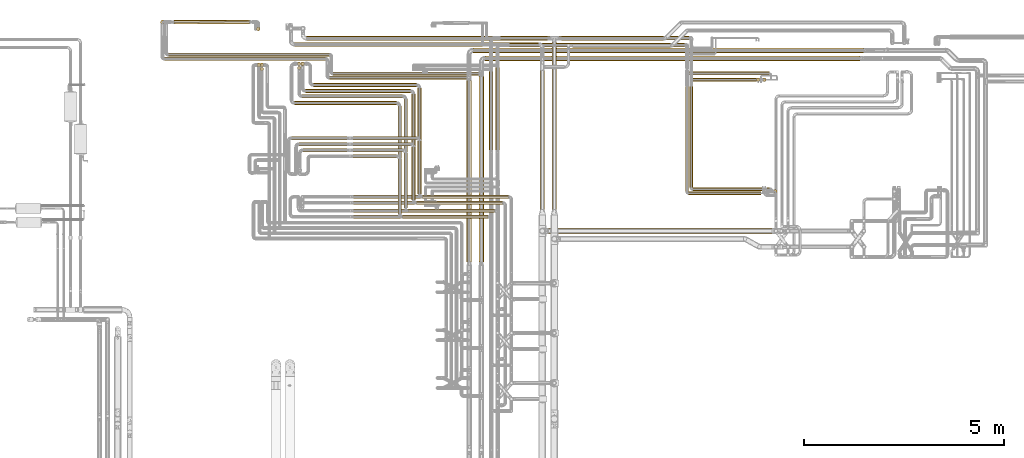
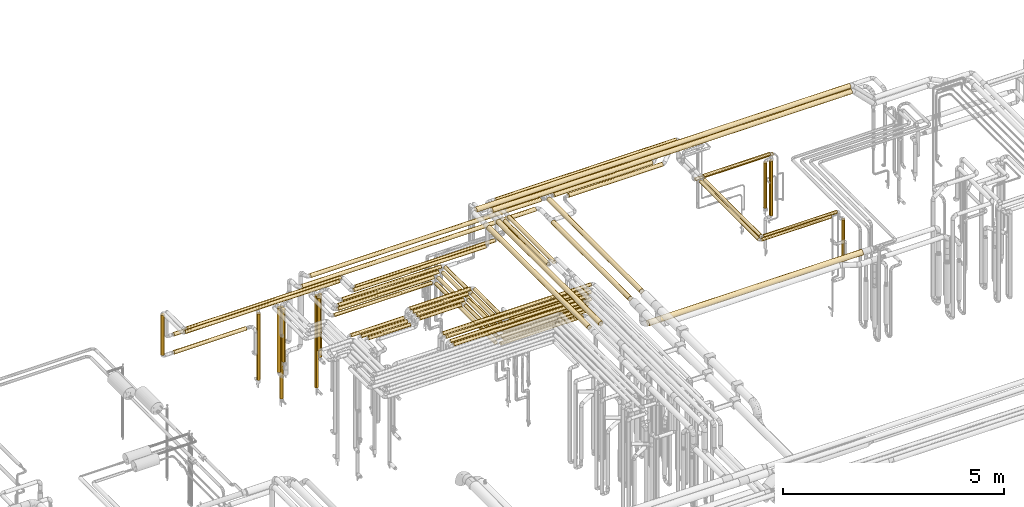
# One storey, part 6 of 827: 69 coverings.
"""IFC2X3 building model written with IfcOpenShell, lengths in millimetres."""

import ifcopenshell
import ifcopenshell.guid

model = None  # the IFC model being written
_history = None  # IfcOwnerHistory: only IFC2X3 demands one
_inside = {}  # id of a spatial element -> (the spatial element, [elements in it])
_under = {}  # id of a project, library or spatial element -> (it, [spatial elements below it])
_declared = {}  # id of a project -> (the project, [libraries it declares])
_typed = {}  # id of a type object -> (the type object, [elements of that type])
_made_of = {}  # id of a material, layer set ... -> (it, [elements and type objects made of it])


def new_model(schema):
    """Start an empty IFC model of exactly this schema.

    Asked for "IFC4X3", IfcOpenShell would pick the latest addendum, in which some entities
    have other attributes; the version numbers below select the first issue.
    IFC2X3 requires an IfcOwnerHistory on every rooted entity: one is made here for all.
    """
    global model, _history
    if schema == "IFC4X3":
        model = ifcopenshell.file(schema_version=(4, 3, 0, 0))
    else:
        model = ifcopenshell.file(schema=schema)
    _inside.clear()
    _under.clear()
    _declared.clear()
    _typed.clear()
    _made_of.clear()
    _history = None
    if model.schema == "IFC2X3":
        org = make("IfcOrganization", Name="unknown")
        user = make(
            "IfcPersonAndOrganization",
            ThePerson=make("IfcPerson", FamilyName="unknown"),
            TheOrganization=org,
        )
        app = make(
            "IfcApplication",
            ApplicationDeveloper=org,
            Version="unknown",
            ApplicationFullName="unknown",
            ApplicationIdentifier="unknown",
        )
        _history = make(
            "IfcOwnerHistory",
            OwningUser=user,
            OwningApplication=app,
            ChangeAction="ADDED",
            CreationDate=0,
        )
    return model


def make(cls, **values):
    """One entity of the class cls with the attributes given. An attribute that is None is left unset."""
    return model.create_entity(
        cls, **{name: value for name, value in values.items() if value is not None}
    )


def entity(cls, *values):
    """Any entity or typed value of the class cls, its attributes in the order of the schema. None: left unset."""
    e = model.create_entity(cls)
    for i, value in enumerate(values):
        if value is not None:
            e[i] = value
    return e


def rooted(cls, **values):
    """An entity with a GlobalId (a new one), such as an element, a storey or a relation."""
    return make(cls, GlobalId=ifcopenshell.guid.new(), OwnerHistory=_history, **values)


def si_unit(unit_type, name, prefix=None):
    """IfcSIUnit, for example si_unit("LENGTHUNIT", "METRE", prefix="MILLI")."""
    return make("IfcSIUnit", UnitType=unit_type, Prefix=prefix, Name=name)


def converted_unit(unit_type, name, factor, base, dimensions=None, offset=None):
    """IfcConversionBasedUnit, such as the inch: factor (a typed value) times the base unit."""
    return make(
        "IfcConversionBasedUnit"
        if offset is None
        else "IfcConversionBasedUnitWithOffset",
        ConversionOffset=offset,
        Dimensions=None
        if dimensions is None
        else entity("IfcDimensionalExponents", *dimensions),
        UnitType=unit_type,
        Name=name,
        ConversionFactor=make(
            "IfcMeasureWithUnit", ValueComponent=factor, UnitComponent=base
        ),
    )


def derived_unit(unit_type, elements):
    """IfcDerivedUnit: a product of units, each with its exponent."""
    return make(
        "IfcDerivedUnit",
        Elements=[
            make("IfcDerivedUnitElement", Unit=unit, Exponent=power)
            for unit, power in elements
        ],
        UnitType=unit_type,
    )


def assignment(units):
    """IfcUnitAssignment: the units of a project."""
    return None if units is None else make("IfcUnitAssignment", Units=units)


def point(xyz):
    """IfcCartesianPoint."""
    return None if xyz is None else make("IfcCartesianPoint", Coordinates=xyz)


def direction(xyz):
    """IfcDirection."""
    return None if xyz is None else make("IfcDirection", DirectionRatios=xyz)


def frame(location, z_axis=None, x_axis=None):
    """IfcAxis2Placement3D, a coordinate frame: its origin and axes. An axis left out is left unset."""
    return make(
        "IfcAxis2Placement3D",
        Location=point(location),
        Axis=direction(z_axis),
        RefDirection=direction(x_axis),
    )


def frame_2d(location, x_axis=None):
    """IfcAxis2Placement2D, a coordinate frame in the plane: its origin and x axis."""
    return make(
        "IfcAxis2Placement2D", Location=point(location), RefDirection=direction(x_axis)
    )


def origin():
    """The frame at (0, 0, 0) with its axes left unset."""
    return frame((0.0, 0.0, 0.0))


def origin_2d_with_axis():
    """The frame at (0, 0) in the plane with the x axis (1, 0) written out."""
    return frame_2d((0.0, 0.0), x_axis=(1.0, 0.0))


def place(relative_to, where):
    """IfcLocalPlacement: puts the frame where relative to a parent placement (None: the world)."""
    return make(
        "IfcLocalPlacement", PlacementRelTo=relative_to, RelativePlacement=where
    )


def context(
    kind, dimensions, precision=None, world=None, true_north=None, identifier=None
):
    """IfcGeometricRepresentationContext, for example the 3D "Model" context."""
    return make(
        "IfcGeometricRepresentationContext",
        ContextIdentifier=identifier,
        ContextType=kind,
        CoordinateSpaceDimension=dimensions,
        Precision=precision,
        WorldCoordinateSystem=world,
        TrueNorth=true_north,
    )


def subcontext(parent, identifier, kind, view, scale=None):
    """IfcGeometricRepresentationSubContext, for example "Body" below "Model"."""
    return make(
        "IfcGeometricRepresentationSubContext",
        ContextIdentifier=identifier,
        ContextType=kind,
        ParentContext=parent,
        TargetScale=scale,
        TargetView=view,
    )


def project(units=None, contexts=None):
    """IfcProject with its units and contexts."""
    return rooted(
        "IfcProject",
        Name="project",
        RepresentationContexts=contexts,
        UnitsInContext=assignment(units),
    )


def spatial(cls, under=None, at=None, **own):
    """A site, building, storey or space (cls), placed at a placement, below another one or the project."""
    s = rooted(cls, ObjectPlacement=at, **own)
    if under is not None:
        _under.setdefault(under.id(), (under, []))[1].append(s)
    return s


def polyline(points):
    """IfcPolyline through the points."""
    return make("IfcPolyline", Points=[point(p) for p in points])


def profile(cls, at=None, kind="AREA", **sizes):
    """A parametric profile (cls). Its sizes go by their IFC names, for example OverallWidth=200.0."""
    return make(cls, ProfileType=kind, Position=at, **sizes)


def circle(**sizes):
    """IfcCircleProfileDef."""
    return profile("IfcCircleProfileDef", **sizes)


def outline(outer, holes=None, kind="AREA"):
    """IfcArbitraryClosedProfileDef: a profile drawn as a closed curve; with holes, ...WithVoids."""
    if holes is None:
        return make("IfcArbitraryClosedProfileDef", ProfileType=kind, OuterCurve=outer)
    return make(
        "IfcArbitraryProfileDefWithVoids",
        ProfileType=kind,
        OuterCurve=outer,
        InnerCurves=holes,
    )


def extrude(swept, where, along, depth):
    """IfcExtrudedAreaSolid: the profile swept, set in the frame where, extruded along a direction by depth."""
    return make(
        "IfcExtrudedAreaSolid",
        SweptArea=swept,
        Position=where,
        ExtrudedDirection=direction(along),
        Depth=depth,
    )


def shape(context_of_items, identifier, shape_type, items):
    """IfcShapeRepresentation: the items that make up one representation, for example the "Body"."""
    return make(
        "IfcShapeRepresentation",
        ContextOfItems=context_of_items,
        RepresentationIdentifier=identifier,
        RepresentationType=shape_type,
        Items=items,
    )


def made_of(thing, what):
    """Note that an element or type object is made of a material, layer set ...; save() writes the relation."""
    if what is not None:
        _made_of.setdefault(what.id(), (what, []))[1].append(thing)
    return thing


def element(
    cls,
    number,
    at=None,
    inside=None,
    cuts=None,
    type_object=None,
    material=None,
    context=None,
    identifier="Body",
    shape_type=None,
    held_by="IfcProductDefinitionShape",
    body=None,
    shapes=None,
    **own,
):
    """One element of the class cls, such as IfcWall. Its Tag is "e" and its number.

    at: its placement. inside: the storey or other place that contains it. cuts: it is an
    opening in that element (IfcRelVoidsElement). A single representation is given by context,
    identifier, shape_type and body (its items); several are given by shapes. held_by: the class
    of the entity that holds the representations. save() writes the other relations.
    """
    e = rooted(cls, Tag="e%d" % number, ObjectPlacement=at, **own)
    if body is not None:
        shapes = [shape(context, identifier, shape_type, body)]
    if shapes is not None:
        e.Representation = make(held_by, Representations=shapes)
    if inside is not None:
        _inside.setdefault(inside.id(), (inside, []))[1].append(e)
    if cuts is not None:
        rooted(
            "IfcRelVoidsElement", RelatingBuildingElement=cuts, RelatedOpeningElement=e
        )
    if type_object is not None:
        _typed.setdefault(type_object.id(), (type_object, []))[1].append(e)
    return made_of(e, material)


def aggregate(whole, parts):
    """IfcRelAggregates: a whole, such as a stair, and the parts it consists of."""
    return rooted("IfcRelAggregates", RelatingObject=whole, RelatedObjects=parts)


def save(model, path):
    """Write the relations noted so far, then the file.

    IfcRelAggregates (storeys below a building ...), IfcRelContainedInSpatialStructure (elements
    in a storey), IfcRelDefinesByType, IfcRelAssociatesMaterial and IfcRelDeclares: one each for
    every whole, place, type object, material and project.
    """
    for whole, parts in _under.values():
        aggregate(whole, parts)
    for where, things in _inside.values():
        rooted(
            "IfcRelContainedInSpatialStructure",
            RelatedElements=things,
            RelatingStructure=where,
        )
    for kind, things in _typed.values():
        rooted("IfcRelDefinesByType", RelatedObjects=things, RelatingType=kind)
    for what, things in _made_of.values():
        rooted("IfcRelAssociatesMaterial", RelatedObjects=things, RelatingMaterial=what)
    for by, libraries in _declared.values():
        rooted("IfcRelDeclares", RelatingContext=by, RelatedDefinitions=libraries)
    model.write(path)


model = new_model("IFC2X3")

# Units and contexts
model_context = context("Model", 3, precision=0.01, world=origin(), true_north=direction((6.12303176911189e-17, 1.0)))
body_context = subcontext(model_context, "Body", "Model", "MODEL_VIEW")
ifc_project = project(units=[si_unit("LENGTHUNIT", "METRE", prefix="MILLI"), si_unit("AREAUNIT", "SQUARE_METRE"), si_unit("VOLUMEUNIT", "CUBIC_METRE"), converted_unit("PLANEANGLEUNIT", "DEGREE", entity("IfcRatioMeasure", 0.0174532925199433), si_unit("PLANEANGLEUNIT", "RADIAN"), dimensions=[0, 0, 0, 0, 0, 0, 0]), si_unit("MASSUNIT", "GRAM", prefix="KILO"), derived_unit("MASSDENSITYUNIT", [(si_unit("MASSUNIT", "GRAM", prefix="KILO"), 1), (si_unit("LENGTHUNIT", "METRE"), -3)]), derived_unit("MOMENTOFINERTIAUNIT", [(si_unit("LENGTHUNIT", "METRE"), 4)]), si_unit("TIMEUNIT", "SECOND"), si_unit("FREQUENCYUNIT", "HERTZ"), si_unit("THERMODYNAMICTEMPERATUREUNIT", "DEGREE_CELSIUS"), derived_unit("THERMALTRANSMITTANCEUNIT", [(si_unit("MASSUNIT", "GRAM", prefix="KILO"), 1), (si_unit("THERMODYNAMICTEMPERATUREUNIT", "KELVIN"), -1), (si_unit("TIMEUNIT", "SECOND"), -3)]), derived_unit("VOLUMETRICFLOWRATEUNIT", [(si_unit("LENGTHUNIT", "METRE"), 3), (si_unit("TIMEUNIT", "SECOND"), -1)]), derived_unit("MASSFLOWRATEUNIT", [(si_unit("MASSUNIT", "GRAM", prefix="KILO"), 1), (si_unit("TIMEUNIT", "SECOND"), -1)]), derived_unit("ROTATIONALFREQUENCYUNIT", [(si_unit("TIMEUNIT", "SECOND"), -1)]), si_unit("ELECTRICCURRENTUNIT", "AMPERE"), si_unit("ELECTRICVOLTAGEUNIT", "VOLT"), si_unit("POWERUNIT", "WATT"), si_unit("FORCEUNIT", "NEWTON", prefix="KILO"), si_unit("ILLUMINANCEUNIT", "LUX"), si_unit("LUMINOUSFLUXUNIT", "LUMEN"), si_unit("LUMINOUSINTENSITYUNIT", "CANDELA"), derived_unit("USERDEFINED", [(si_unit("MASSUNIT", "GRAM", prefix="KILO"), -1), (si_unit("LENGTHUNIT", "METRE"), -2), (si_unit("TIMEUNIT", "SECOND"), 3), (si_unit("LUMINOUSFLUXUNIT", "LUMEN"), 1)]), derived_unit("LINEARVELOCITYUNIT", [(si_unit("LENGTHUNIT", "METRE"), 1), (si_unit("TIMEUNIT", "SECOND"), -1)]), si_unit("PRESSUREUNIT", "PASCAL"), derived_unit("USERDEFINED", [(si_unit("LENGTHUNIT", "METRE"), -2), (si_unit("MASSUNIT", "GRAM", prefix="KILO"), 1), (si_unit("TIMEUNIT", "SECOND"), -2)]), derived_unit("LINEARFORCEUNIT", [(si_unit("MASSUNIT", "GRAM", prefix="KILO"), 1), (si_unit("LENGTHUNIT", "METRE"), 1), (si_unit("TIMEUNIT", "SECOND"), -2), (si_unit("LENGTHUNIT", "METRE"), -1)]), derived_unit("PLANARFORCEUNIT", [(si_unit("MASSUNIT", "GRAM", prefix="KILO"), 1), (si_unit("LENGTHUNIT", "METRE"), 1), (si_unit("TIMEUNIT", "SECOND"), -2), (si_unit("LENGTHUNIT", "METRE"), -2)])], contexts=[model_context])

# Site, building, storey
site_placement = place(None, origin())
site = spatial("IfcSite", under=ifc_project, at=site_placement, CompositionType="ELEMENT")
building_placement = place(site_placement, origin())
building = spatial("IfcBuilding", under=site, at=building_placement, CompositionType="ELEMENT")
storey_placement = place(building_placement, frame((0.0, 0.0, 28200.0)))
storey = spatial("IfcBuildingStorey", under=building, at=storey_placement, Name="08", CompositionType="ELEMENT", Elevation=28200.0)

# Coverings
covering_1_placement = place(storey_placement, frame((36012.93, 18744.53, 3485.65)))
element("IfcCovering", 1, at=covering_1_placement, inside=storey, Name=":ADSK_", ObjectType=":ADSK_", PredefinedType="INSULATION", context=body_context, shape_type="SweptSolid", body=[
    extrude(outline(polyline([(-8.19, -62.21), (8.19, -62.21), (24.01, -57.97), (38.2, -49.78), (49.78, -38.2), (57.97, -24.01), (62.21, -8.19), (62.21, 8.19), (57.97, 24.01), (49.78, 38.2), (38.2, 49.78), (24.01, 57.97), (8.19, 62.21), (-8.19, 62.21), (-24.01, 57.97), (-38.2, 49.78), (-49.78, 38.2), (-57.97, 24.01), (-62.21, 8.19), (-62.21, -8.19), (-57.97, -24.01), (-49.78, -38.2), (-38.2, -49.78), (-24.01, -57.97), (-8.19, -62.21)])), frame((0.0, 64.39, 64.35), z_axis=(1.0, -4.85826303863744e-06, 0.0), x_axis=(6.34811881532513e-07, 0.130526192218576, -0.991444861373802)), (0.0, 0.0, 1.0), 9771.5320502305),
])
covering_2_placement = place(storey_placement, frame((28192.29, 19468.46, 1848.0)))
element("IfcCovering", 2, at=covering_2_placement, inside=storey, Name=":ADSK_", ObjectType=":ADSK_", PredefinedType="INSULATION", context=body_context, shape_type="SweptSolid", body=[
    extrude(circle(Radius=46.15, at=origin_2d_with_axis()), frame((47.75, 47.75, 0.0)), (0.0, 0.0, 1.0), 1103.5044787345),
])
covering_3_placement = place(storey_placement, frame((28288.03, 18549.76, 2951.76)))
element("IfcCovering", 3, at=covering_3_placement, inside=storey, Name=":ADSK_", ObjectType=":ADSK_", PredefinedType="INSULATION", context=body_context, shape_type="SweptSolid", body=[
    extrude(circle(Radius=46.15, at=origin_2d_with_axis()), frame((0.0, 47.75, 47.75), z_axis=(1.0, 0.0, 0.0), x_axis=(0.0, 1.0, 0.0)), (0.0, 0.0, 1.0), 4034.00000000001),
])
covering_4_placement = place(storey_placement, frame((32418.03, 18077.16, 2951.76)))
element("IfcCovering", 4, at=covering_4_placement, inside=storey, Name=":ADSK_", ObjectType=":ADSK_", PredefinedType="INSULATION", context=body_context, shape_type="SweptSolid", body=[
    extrude(circle(Radius=46.15, at=origin_2d_with_axis()), frame((0.0, 47.75, 47.75), z_axis=(1.0, -2.64804923458862e-08, -1.57061026051097e-07), x_axis=(2.64804923458866e-08, 1.0, 0.0)), (0.0, 0.0, 1.0), 3452.34056165486),
])
covering_5_placement = place(storey_placement, frame((35853.75, 13506.7, 3485.65)))
element("IfcCovering", 5, at=covering_5_placement, inside=storey, Name=":ADSK_", ObjectType=":ADSK_", PredefinedType="INSULATION", context=body_context, shape_type="SweptSolid", body=[
    extrude(circle(Radius=62.75, at=origin_2d_with_axis()), frame((64.35, 0.0, 64.35), z_axis=(0.0, 1.0, -9.47129949639456e-08), x_axis=(-1.0, 0.0, 0.0)), (0.0, 0.0, 1.0), 4542.20661769209),
])
covering_6_placement = place(storey_placement, frame((28529.16, 19465.54, 1749.4)))
element("IfcCovering", 6, at=covering_6_placement, inside=storey, Name=":ADSK_", ObjectType=":ADSK_", PredefinedType="INSULATION", context=body_context, shape_type="SweptSolid", body=[
    extrude(circle(Radius=49.0, at=origin_2d_with_axis()), frame((0.06, 50.6, 50.6), z_axis=(0.999999363543567, 0.00112823422292339, 0.0), x_axis=(-0.00112823422292339, 0.999999363543567, 0.0)), (0.0, 0.0, 1.0), 1888.98967089916),
])
covering_7_placement = place(storey_placement, frame((30594.46, 19295.69, 423.0)))
element("IfcCovering", 7, at=covering_7_placement, inside=storey, Name=":ADSK_", ObjectType=":ADSK_", PredefinedType="INSULATION", context=body_context, shape_type="SweptSolid", body=[
    extrude(circle(Radius=46.15, at=origin_2d_with_axis()), frame((47.75, 47.75, 0.0)), (0.0, 0.0, 1.0), 1829.00000000023),
])
covering_8_placement = place(storey_placement, frame((36315.03, 18542.35, 3485.65)))
element("IfcCovering", 8, at=covering_8_placement, inside=storey, Name=":ADSK_", ObjectType=":ADSK_", PredefinedType="INSULATION", context=body_context, shape_type="SweptSolid", body=[
    extrude(circle(Radius=62.75, at=origin_2d_with_axis()), frame((0.0, 64.35, 64.35), z_axis=(1.0, 0.0, 0.0), x_axis=(0.0, -1.0, 0.0)), (0.0, 0.0, 1.0), 9389.4356787662),
])
covering_9_placement = place(storey_placement, frame((36155.69, 13506.7, 3485.65)))
element("IfcCovering", 9, at=covering_9_placement, inside=storey, Name=":ADSK_", ObjectType=":ADSK_", PredefinedType="INSULATION", context=body_context, shape_type="SweptSolid", body=[
    extrude(circle(Radius=62.75, at=origin_2d_with_axis()), frame((64.35, 0.0, 64.35), z_axis=(0.0, 1.0, 0.0), x_axis=(1.0, 0.0, 0.0)), (0.0, 0.0, 1.0), 4642.2472086319),
])
covering_10_placement = place(storey_placement, frame((28388.03, 18652.26, 2952.16)))
element("IfcCovering", 10, at=covering_10_placement, inside=storey, Name=":ADSK_", ObjectType=":ADSK_", PredefinedType="INSULATION", context=body_context, shape_type="SweptSolid", body=[
    extrude(circle(Radius=46.15, at=origin_2d_with_axis()), frame((0.0, 47.75, 47.75), z_axis=(1.0, 0.0, 0.0), x_axis=(0.0, 1.0, 0.0)), (0.0, 0.0, 1.0), 4031.49999999999),
])
covering_11_placement = place(storey_placement, frame((32515.53, 18177.2, 2952.42)))
element("IfcCovering", 11, at=covering_11_placement, inside=storey, Name=":ADSK_", ObjectType=":ADSK_", PredefinedType="INSULATION", context=body_context, shape_type="SweptSolid", body=[
    extrude(circle(Radius=46.15, at=origin_2d_with_axis()), frame((0.0, 47.75, 47.75), z_axis=(1.0, 0.0, 0.0), x_axis=(0.0, 1.0, 0.0)), (0.0, 0.0, 1.0), 3656.50789865934),
])
covering_12_placement = place(storey_placement, frame((28524.22, 19465.61, 2249.4)))
element("IfcCovering", 12, at=covering_12_placement, inside=storey, Name=":ADSK_", ObjectType=":ADSK_", PredefinedType="INSULATION", context=body_context, shape_type="SweptSolid", body=[
    extrude(circle(Radius=49.0, at=origin_2d_with_axis()), frame((0.0, 50.6, 50.6), z_axis=(1.0, 0.0, 0.0), x_axis=(0.0, -1.0, 0.0)), (0.0, 0.0, 1.0), 1893.98090500761),
])
covering_13_placement = place(storey_placement, frame((30677.33, 18293.46, 1500.5)))
element("IfcCovering", 13, at=covering_13_placement, inside=storey, Name=":ADSK_", ObjectType=":ADSK_", PredefinedType="INSULATION", context=body_context, shape_type="SweptSolid", body=[
    extrude(circle(Radius=46.15, at=origin_2d_with_axis()), frame((47.75, 47.75, 0.0), z_axis=(0.0, 0.0, 1.0), x_axis=(0.0, -1.0, 0.0)), (0.0, 0.0, 1.0), 1451.5),
])
covering_14_placement = place(storey_placement, frame((30677.33, 18393.46, 423.0)))
element("IfcCovering", 14, at=covering_14_placement, inside=storey, Name=":ADSK_", ObjectType=":ADSK_", PredefinedType="INSULATION", context=body_context, shape_type="SweptSolid", body=[
    extrude(circle(Radius=46.15, at=origin_2d_with_axis()), frame((47.75, 47.75, 0.0), z_axis=(0.0, 0.0, 1.0), x_axis=(0.0, -1.0, 0.0)), (0.0, 0.0, 1.0), 2529.00000000008),
])
covering_15_placement = place(storey_placement, frame((30609.3, 18393.46, 1178.45)))
element("IfcCovering", 15, at=covering_15_placement, inside=storey, Name=":ADSK_", ObjectType=":ADSK_", PredefinedType="INSULATION", context=body_context, shape_type="SweptSolid", body=[
    extrude(circle(Radius=46.15, at=origin_2d_with_axis()), frame((47.75, 47.75, 0.0), z_axis=(0.0, 0.0, 1.0), x_axis=(0.0, 1.0, 0.0)), (0.0, 0.0, 1.0), 1773.55173999997),
])
covering_16_placement = place(storey_placement, frame((38500.22, 18877.0, 2945.65)))
element("IfcCovering", 16, at=covering_16_placement, inside=storey, Name=":ADSK_", ObjectType=":ADSK_", PredefinedType="INSULATION", context=body_context, shape_type="SweptSolid", body=[
    extrude(circle(Radius=52.75, at=origin_2d_with_axis()), frame((0.0, 54.35, 54.35), z_axis=(1.0, 0.0, 0.0), x_axis=(0.0, -1.0, 0.0)), (0.0, 0.0, 1.0), 2456.78207897576),
])
covering_17_placement = place(storey_placement, frame((31545.66, 17444.61, 2953.4)))
element("IfcCovering", 17, at=covering_17_placement, inside=storey, Name=":ADSK_", ObjectType=":ADSK_", PredefinedType="INSULATION", context=body_context, shape_type="SweptSolid", body=[
    extrude(circle(Radius=45.0, at=origin_2d_with_axis()), frame((0.0, 46.6, 46.6), z_axis=(1.0, 0.0, 0.0), x_axis=(0.0, 1.0, 0.0)), (0.0, 0.0, 1.0), 2553.37052000001),
])
covering_18_placement = place(storey_placement, frame((34128.44, 14716.0, 2953.4)))
element("IfcCovering", 18, at=covering_18_placement, inside=storey, Name=":ADSK_", ObjectType=":ADSK_", PredefinedType="INSULATION", context=body_context, shape_type="SweptSolid", body=[
    extrude(circle(Radius=45.0, at=origin_2d_with_axis()), frame((46.6, 0.0, 46.6), z_axis=(0.0, 1.0, 0.0), x_axis=(-1.0, 0.0, 0.0)), (0.0, 0.0, 1.0), 2699.20292594585),
])
covering_19_placement = place(storey_placement, frame((31615.07, 18424.61, 379.5)))
element("IfcCovering", 19, at=covering_19_placement, inside=storey, Name=":ADSK_", ObjectType=":ADSK_", PredefinedType="INSULATION", context=body_context, shape_type="SweptSolid", body=[
    extrude(circle(Radius=45.0, at=origin_2d_with_axis()), frame((46.6, 46.6, 0.0), z_axis=(0.0, 0.0, 1.0), x_axis=(0.0, 1.0, 0.0)), (0.0, 0.0, 1.0), 2544.50000000013),
])
covering_20_placement = place(storey_placement, frame((34251.03, 14593.41, 2953.4)))
element("IfcCovering", 20, at=covering_20_placement, inside=storey, Name=":ADSK_", ObjectType=":ADSK_", PredefinedType="INSULATION", context=body_context, shape_type="SweptSolid", body=[
    extrude(circle(Radius=45.0, at=origin_2d_with_axis()), frame((0.0, 46.6, 46.6), z_axis=(1.0, 0.0, 0.0), x_axis=(0.0, 1.0, 0.0)), (0.0, 0.0, 1.0), 2143.00000000003),
])
covering_21_placement = place(storey_placement, frame((31550.41, 18902.64, 2845.49)))
element("IfcCovering", 21, at=covering_21_placement, inside=storey, Name=":ADSK_", ObjectType=":ADSK_", PredefinedType="INSULATION", context=body_context, shape_type="SweptSolid", body=[
    extrude(circle(Radius=53.0, at=origin_2d_with_axis()), frame((0.0, 54.6, 54.6), z_axis=(1.0, 0.0, 0.0), x_axis=(0.0, -1.0, 0.0)), (0.0, 0.0, 1.0), 6102.89199936658),
])
covering_22_placement = place(storey_placement, frame((31737.66, 17613.61, 2953.4)))
element("IfcCovering", 22, at=covering_22_placement, inside=storey, Name=":ADSK_", ObjectType=":ADSK_", PredefinedType="INSULATION", context=body_context, shape_type="SweptSolid", body=[
    extrude(circle(Radius=45.0, at=origin_2d_with_axis()), frame((0.0, 46.6, 46.6), z_axis=(1.0, 0.0, 0.0), x_axis=(0.0, 1.0, 0.0)), (0.0, 0.0, 1.0), 2513.00001774619),
])
covering_23_placement = place(storey_placement, frame((34280.07, 14866.0, 2953.4)))
element("IfcCovering", 23, at=covering_23_placement, inside=storey, Name=":ADSK_", ObjectType=":ADSK_", PredefinedType="INSULATION", context=body_context, shape_type="SweptSolid", body=[
    extrude(circle(Radius=45.0, at=origin_2d_with_axis()), frame((46.6, 0.0, 46.6), z_axis=(0.0, 1.0, 0.0), x_axis=(1.0, 0.0, 0.0)), (0.0, 0.0, 1.0), 2718.20272594582),
])
covering_24_placement = place(storey_placement, frame((34402.66, 14743.41, 2953.4)))
element("IfcCovering", 24, at=covering_24_placement, inside=storey, Name=":ADSK_", ObjectType=":ADSK_", PredefinedType="INSULATION", context=body_context, shape_type="SweptSolid", body=[
    extrude(circle(Radius=45.0, at=origin_2d_with_axis()), frame((0.0, 46.6, 46.6), z_axis=(1.0, 0.0, 0.0), x_axis=(0.0, 1.0, 0.0)), (0.0, 0.0, 1.0), 2150.98068574385),
])
covering_25_placement = place(storey_placement, frame((34251.03, 14593.41, 3153.4)))
element("IfcCovering", 25, at=covering_25_placement, inside=storey, Name=":ADSK_", ObjectType=":ADSK_", PredefinedType="INSULATION", context=body_context, shape_type="SweptSolid", body=[
    extrude(circle(Radius=45.0, at=origin_2d_with_axis()), frame((0.0, 46.6, 46.6), z_axis=(1.0, 0.0, 0.0), x_axis=(0.0, 1.0, 0.0)), (0.0, 0.0, 1.0), 2143.00000000005),
])
covering_26_placement = place(storey_placement, frame((34402.66, 14743.41, 3153.4)))
element("IfcCovering", 26, at=covering_26_placement, inside=storey, Name=":ADSK_", ObjectType=":ADSK_", PredefinedType="INSULATION", context=body_context, shape_type="SweptSolid", body=[
    extrude(circle(Radius=45.0, at=origin_2d_with_axis()), frame((0.0, 46.6, 46.6), z_axis=(1.0, 0.0, 0.0), x_axis=(0.0, 1.0, 0.0)), (0.0, 0.0, 1.0), 2150.98068574388),
])
covering_27_placement = place(storey_placement, frame((33021.03, 14593.41, 3353.4)))
element("IfcCovering", 27, at=covering_27_placement, inside=storey, Name=":ADSK_", ObjectType=":ADSK_", PredefinedType="INSULATION", context=body_context, shape_type="SweptSolid", body=[
    extrude(circle(Radius=45.0, at=origin_2d_with_axis()), frame((0.0, 46.6, 46.6), z_axis=(1.0, 0.0, 0.0), x_axis=(0.0, -1.0, 0.0)), (0.0, 0.0, 1.0), 3373.00000900002),
])
covering_28_placement = place(storey_placement, frame((33021.03, 14743.41, 3353.4)))
element("IfcCovering", 28, at=covering_28_placement, inside=storey, Name=":ADSK_", ObjectType=":ADSK_", PredefinedType="INSULATION", context=body_context, shape_type="SweptSolid", body=[
    extrude(circle(Radius=45.0, at=origin_2d_with_axis()), frame((0.0, 46.6, 46.6), z_axis=(1.0, 0.0, 0.0), x_axis=(0.0, -1.0, 0.0)), (0.0, 0.0, 1.0), 3532.61017471227),
])
covering_29_placement = place(storey_placement, frame((34128.44, 14716.0, 3153.4)))
element("IfcCovering", 29, at=covering_29_placement, inside=storey, Name=":ADSK_", ObjectType=":ADSK_", PredefinedType="INSULATION", context=body_context, shape_type="SweptSolid", body=[
    extrude(circle(Radius=45.0, at=origin_2d_with_axis()), frame((46.6, 0.0, 46.6), z_axis=(0.0, 1.0, 0.0), x_axis=(1.0, 0.0, 0.0)), (0.0, 0.0, 1.0), 1369.20291694587),
])
covering_30_placement = place(storey_placement, frame((34280.07, 14866.0, 3153.4)))
element("IfcCovering", 30, at=covering_30_placement, inside=storey, Name=":ADSK_", ObjectType=":ADSK_", PredefinedType="INSULATION", context=body_context, shape_type="SweptSolid", body=[
    extrude(circle(Radius=45.0, at=origin_2d_with_axis()), frame((46.6, 0.0, 46.6), z_axis=(0.0, 1.0, 0.0), x_axis=(-1.0, 0.0, 0.0)), (0.0, 0.0, 1.0), 1369.20271676073),
])
covering_31_placement = place(storey_placement, frame((33011.03, 16114.61, 3153.4)))
element("IfcCovering", 31, at=covering_31_placement, inside=storey, Name=":ADSK_", ObjectType=":ADSK_", PredefinedType="INSULATION", context=body_context, shape_type="SweptSolid", body=[
    extrude(circle(Radius=45.0, at=origin_2d_with_axis()), frame((0.0, 46.6, 46.6), z_axis=(1.0, 0.0, 0.0), x_axis=(0.0, -1.0, 0.0)), (0.0, 0.0, 1.0), 1088.00000000002),
])
covering_32_placement = place(storey_placement, frame((33011.03, 16264.61, 3153.4)))
element("IfcCovering", 32, at=covering_32_placement, inside=storey, Name=":ADSK_", ObjectType=":ADSK_", PredefinedType="INSULATION", context=body_context, shape_type="SweptSolid", body=[
    extrude(circle(Radius=45.0, at=origin_2d_with_axis()), frame((0.0, 46.6, 46.6), z_axis=(1.0, 0.0, 0.0), x_axis=(0.0, -1.0, 0.0)), (0.0, 0.0, 1.0), 1239.62947996842),
])
covering_33_placement = place(storey_placement, frame((31756.25, 16264.61, 2953.4)))
element("IfcCovering", 33, at=covering_33_placement, inside=storey, Name=":ADSK_", ObjectType=":ADSK_", PredefinedType="INSULATION", context=body_context, shape_type="SweptSolid", body=[
    extrude(circle(Radius=45.0, at=origin_2d_with_axis()), frame((0.0, 46.6, 46.6), z_axis=(1.0, 0.0, 0.0), x_axis=(0.0, -1.0, 0.0)), (0.0, 0.0, 1.0), 1102.78000899999),
])
covering_34_placement = place(storey_placement, frame((31615.07, 18320.35, 1469.5)))
element("IfcCovering", 34, at=covering_34_placement, inside=storey, Name=":ADSK_", ObjectType=":ADSK_", PredefinedType="INSULATION", context=body_context, shape_type="SweptSolid", body=[
    extrude(circle(Radius=45.0, at=origin_2d_with_axis()), frame((46.6, 46.6, 0.0), z_axis=(0.0, 0.0, 1.0), x_axis=(0.0, 1.0, 0.0)), (0.0, 0.0, 1.0), 1454.50000000077),
])
covering_35_placement = place(storey_placement, frame((37687.2, 14827.72, 2838.86)))
element("IfcCovering", 35, at=covering_35_placement, inside=storey, Name=":ADSK_", ObjectType=":ADSK_", PredefinedType="INSULATION", context=body_context, shape_type="SweptSolid", body=[
    extrude(circle(Radius=59.5, at=origin_2d_with_axis()), frame((61.1, 0.0, 61.1), z_axis=(0.0, 1.0, 3.91458551998914e-05), x_axis=(-1.0, 0.0, 0.0)), (0.0, 0.0, 1.0), 3480.66550139349),
])
covering_36_placement = place(storey_placement, frame((43259.74, 18027.89, 1297.88)))
element("IfcCovering", 36, at=covering_36_placement, inside=storey, Name=":ADSK_", ObjectType=":ADSK_", PredefinedType="INSULATION", context=body_context, shape_type="SweptSolid", body=[
    extrude(circle(Radius=41.75, at=origin_2d_with_axis()), frame((43.35, 43.35, 0.0), z_axis=(0.0, 0.0, 1.0), x_axis=(0.0, -1.0, 0.0)), (0.0, 0.0, 1.0), 1514.12352106977),
])
covering_37_placement = place(storey_placement, frame((43109.74, 18027.59, 1557.25)))
element("IfcCovering", 37, at=covering_37_placement, inside=storey, Name=":ADSK_", ObjectType=":ADSK_", PredefinedType="INSULATION", context=body_context, shape_type="SweptSolid", body=[
    extrude(circle(Radius=41.75, at=origin_2d_with_axis()), frame((43.35, 43.35, 0.0), z_axis=(0.0, 0.0, 1.0), x_axis=(0.0, -1.0, 0.0)), (0.0, 0.0, 1.0), 1254.75207132545),
])
covering_38_placement = place(storey_placement, frame((43532.87, 15237.98, 1737.28)))
element("IfcCovering", 38, at=covering_38_placement, inside=storey, Name=":ADSK_", ObjectType=":ADSK_", PredefinedType="INSULATION", context=body_context, shape_type="SweptSolid", body=[
    extrude(circle(Radius=41.75, at=origin_2d_with_axis()), frame((43.35, 43.35, 0.0), z_axis=(0.0, 0.0, 1.0), x_axis=(0.0, 1.0, 0.0)), (0.0, 0.0, 1.0), 1046.92285172848),
])
covering_39_placement = place(storey_placement, frame((36697.02, 19064.89, 3349.3)))
element("IfcCovering", 39, at=covering_39_placement, inside=storey, Name=":ADSK_", ObjectType=":ADSK_", PredefinedType="INSULATION", context=body_context, shape_type="SweptSolid", body=[
    extrude(circle(Radius=49.0, at=origin_2d_with_axis()), frame((0.0, 50.6, 50.6), z_axis=(1.0, 0.0, 0.0), x_axis=(0.0, -1.0, 0.0)), (0.0, 0.0, 1.0), 4722.19367836544),
])
covering_40_placement = place(storey_placement, frame((36418.12, 16315.93, 3349.3)))
element("IfcCovering", 40, at=covering_40_placement, inside=storey, Name=":ADSK_", ObjectType=":ADSK_", PredefinedType="INSULATION", context=body_context, shape_type="SweptSolid", body=[
    extrude(circle(Radius=49.0, at=origin_2d_with_axis()), frame((50.6, 0.0, 50.6), z_axis=(0.0, 1.0, 0.0), x_axis=(1.0, 0.0, 0.0)), (0.0, 0.0, 1.0), 1961.97743456359),
])
covering_41_placement = place(storey_placement, frame((36922.02, 18885.81, 3349.3)))
element("IfcCovering", 41, at=covering_41_placement, inside=storey, Name=":ADSK_", ObjectType=":ADSK_", PredefinedType="INSULATION", context=body_context, shape_type="SweptSolid", body=[
    extrude(circle(Radius=49.0, at=origin_2d_with_axis()), frame((0.0, 50.6, 50.6), z_axis=(1.0, 1.42382432847069e-05, 0.0), x_axis=(1.42382432847069e-05, -1.0, 0.0)), (0.0, 0.0, 1.0), 4390.35001608479),
])
covering_42_placement = place(storey_placement, frame((36579.05, 16312.49, 3349.3)))
element("IfcCovering", 42, at=covering_42_placement, inside=storey, Name=":ADSK_", ObjectType=":ADSK_", PredefinedType="INSULATION", context=body_context, shape_type="SweptSolid", body=[
    extrude(circle(Radius=49.0, at=origin_2d_with_axis()), frame((50.6, 0.0, 50.6), z_axis=(0.0, 1.0, 0.0), x_axis=(1.0, 0.0, 0.0)), (0.0, 0.0, 1.0), 2065.41871271011),
])
covering_43_placement = place(storey_placement, frame((37987.2, 14827.72, 2938.9)))
element("IfcCovering", 43, at=covering_43_placement, inside=storey, Name=":ADSK_", ObjectType=":ADSK_", PredefinedType="INSULATION", context=body_context, shape_type="SweptSolid", body=[
    extrude(circle(Radius=59.5, at=origin_2d_with_axis()), frame((61.1, 0.0, 61.1), z_axis=(0.0, 1.0, 0.0), x_axis=(1.0, 0.0, 0.0)), (0.0, 0.0, 1.0), 4193.99999999999),
])
covering_44_placement = place(storey_placement, frame((38223.3, 19053.12, 2945.4)))
element("IfcCovering", 44, at=covering_44_placement, inside=storey, Name=":ADSK_", ObjectType=":ADSK_", PredefinedType="INSULATION", context=body_context, shape_type="SweptSolid", body=[
    extrude(circle(Radius=53.0, at=origin_2d_with_axis()), frame((0.0, 54.6, 54.6), z_axis=(1.0, 0.0, 0.0), x_axis=(0.0, -1.0, 0.0)), (0.0, 0.0, 1.0), 2563.05314198827),
])
covering_45_placement = place(storey_placement, frame((31702.07, 18424.61, 1196.13)))
element("IfcCovering", 45, at=covering_45_placement, inside=storey, Name=":ADSK_", ObjectType=":ADSK_", PredefinedType="INSULATION", context=body_context, shape_type="SweptSolid", body=[
    extrude(circle(Radius=45.0, at=origin_2d_with_axis()), frame((46.6, 46.6, 0.0), z_axis=(0.0, 0.0, 1.0), x_axis=(0.0, -1.0, 0.0)), (0.0, 0.0, 1.0), 1727.87245965627),
])
covering_46_placement = place(storey_placement, frame((32016.66, 17894.61, 2953.4)))
element("IfcCovering", 46, at=covering_46_placement, inside=storey, Name=":ADSK_", ObjectType=":ADSK_", PredefinedType="INSULATION", context=body_context, shape_type="SweptSolid", body=[
    extrude(circle(Radius=45.0, at=origin_2d_with_axis()), frame((0.0, 46.6, 46.6), z_axis=(1.0, 0.0, 0.0), x_axis=(0.0, 1.0, 0.0)), (0.0, 0.0, 1.0), 2582.37054110707),
])
covering_47_placement = place(storey_placement, frame((34628.44, 15215.0, 2953.4)))
element("IfcCovering", 47, at=covering_47_placement, inside=storey, Name=":ADSK_", ObjectType=":ADSK_", PredefinedType="INSULATION", context=body_context, shape_type="SweptSolid", body=[
    extrude(circle(Radius=45.0, at=origin_2d_with_axis()), frame((46.6, 0.0, 46.6), z_axis=(0.0, 1.0, 0.0), x_axis=(1.0, 0.0, 0.0)), (0.0, 0.0, 1.0), 2650.20251676074),
])
covering_48_placement = place(storey_placement, frame((34751.03, 15092.41, 2953.4)))
element("IfcCovering", 48, at=covering_48_placement, inside=storey, Name=":ADSK_", ObjectType=":ADSK_", PredefinedType="INSULATION", context=body_context, shape_type="SweptSolid", body=[
    extrude(circle(Radius=45.0, at=origin_2d_with_axis()), frame((0.0, 46.6, 46.6), z_axis=(1.0, 0.0, 0.0), x_axis=(0.0, 1.0, 0.0)), (0.0, 0.0, 1.0), 2148.00000000003),
])
covering_49_placement = place(storey_placement, frame((31824.66, 17744.61, 2953.4)))
element("IfcCovering", 49, at=covering_49_placement, inside=storey, Name=":ADSK_", ObjectType=":ADSK_", PredefinedType="INSULATION", context=body_context, shape_type="SweptSolid", body=[
    extrude(circle(Radius=45.0, at=origin_2d_with_axis()), frame((0.0, 46.6, 46.6), z_axis=(1.0, 0.0, 0.0), x_axis=(0.0, 1.0, 0.0)), (0.0, 0.0, 1.0), 2624.3705410775),
])
covering_50_placement = place(storey_placement, frame((34478.44, 15065.0, 2953.4)))
element("IfcCovering", 50, at=covering_50_placement, inside=storey, Name=":ADSK_", ObjectType=":ADSK_", PredefinedType="INSULATION", context=body_context, shape_type="SweptSolid", body=[
    extrude(circle(Radius=45.0, at=origin_2d_with_axis()), frame((46.6, 0.0, 46.6), z_axis=(0.0, 1.0, 0.0), x_axis=(1.0, 0.0, 0.0)), (0.0, 0.0, 1.0), 2650.20271676073),
])
covering_51_placement = place(storey_placement, frame((34601.03, 14942.41, 2953.4)))
element("IfcCovering", 51, at=covering_51_placement, inside=storey, Name=":ADSK_", ObjectType=":ADSK_", PredefinedType="INSULATION", context=body_context, shape_type="SweptSolid", body=[
    extrude(circle(Radius=45.0, at=origin_2d_with_axis()), frame((0.0, 46.6, 46.6), z_axis=(1.0, 0.0, 0.0), x_axis=(0.0, 1.0, 0.0)), (0.0, 0.0, 1.0), 2148.00000000001),
])
covering_52_placement = place(storey_placement, frame((34751.03, 15092.41, 3153.4)))
element("IfcCovering", 52, at=covering_52_placement, inside=storey, Name=":ADSK_", ObjectType=":ADSK_", PredefinedType="INSULATION", context=body_context, shape_type="SweptSolid", body=[
    extrude(circle(Radius=45.0, at=origin_2d_with_axis()), frame((0.0, 46.6, 46.6), z_axis=(1.0, 0.0, 0.0), x_axis=(0.0, 1.0, 0.0)), (0.0, 0.0, 1.0), 2148.00000000005),
])
covering_53_placement = place(storey_placement, frame((34601.03, 14942.41, 3153.4)))
element("IfcCovering", 53, at=covering_53_placement, inside=storey, Name=":ADSK_", ObjectType=":ADSK_", PredefinedType="INSULATION", context=body_context, shape_type="SweptSolid", body=[
    extrude(circle(Radius=45.0, at=origin_2d_with_axis()), frame((0.0, 46.6, 46.6), z_axis=(1.0, 0.0, 0.0), x_axis=(0.0, 1.0, 0.0)), (0.0, 0.0, 1.0), 2148.00000000003),
])
covering_54_placement = place(storey_placement, frame((33021.03, 15093.41, 3353.4)))
element("IfcCovering", 54, at=covering_54_placement, inside=storey, Name=":ADSK_", ObjectType=":ADSK_", PredefinedType="INSULATION", context=body_context, shape_type="SweptSolid", body=[
    extrude(circle(Radius=45.0, at=origin_2d_with_axis()), frame((0.0, 46.6, 46.6), z_axis=(1.0, 0.0, 0.0), x_axis=(0.0, -1.0, 0.0)), (0.0, 0.0, 1.0), 3878.00000000002),
])
covering_55_placement = place(storey_placement, frame((33021.03, 14943.41, 3353.4)))
element("IfcCovering", 55, at=covering_55_placement, inside=storey, Name=":ADSK_", ObjectType=":ADSK_", PredefinedType="INSULATION", context=body_context, shape_type="SweptSolid", body=[
    extrude(circle(Radius=45.0, at=origin_2d_with_axis()), frame((0.0, 46.6, 46.6), z_axis=(1.0, 0.0, 0.0), x_axis=(0.0, -1.0, 0.0)), (0.0, 0.0, 1.0), 3728.00000000001),
])
covering_56_placement = place(storey_placement, frame((34628.44, 15215.0, 3153.4)))
element("IfcCovering", 56, at=covering_56_placement, inside=storey, Name=":ADSK_", ObjectType=":ADSK_", PredefinedType="INSULATION", context=body_context, shape_type="SweptSolid", body=[
    extrude(circle(Radius=45.0, at=origin_2d_with_axis()), frame((46.6, 0.0, 46.6), z_axis=(0.0, 1.0, 0.0), x_axis=(-1.0, 0.0, 0.0)), (0.0, 0.0, 1.0), 1320.20250776075),
])
covering_57_placement = place(storey_placement, frame((34478.44, 15065.0, 3153.4)))
element("IfcCovering", 57, at=covering_57_placement, inside=storey, Name=":ADSK_", ObjectType=":ADSK_", PredefinedType="INSULATION", context=body_context, shape_type="SweptSolid", body=[
    extrude(circle(Radius=45.0, at=origin_2d_with_axis()), frame((46.6, 0.0, 46.6), z_axis=(0.0, 1.0, 0.0), x_axis=(-1.0, 0.0, 0.0)), (0.0, 0.0, 1.0), 1320.20271676074),
])
covering_58_placement = place(storey_placement, frame((33011.03, 16414.61, 3153.4)))
element("IfcCovering", 58, at=covering_58_placement, inside=storey, Name=":ADSK_", ObjectType=":ADSK_", PredefinedType="INSULATION", context=body_context, shape_type="SweptSolid", body=[
    extrude(circle(Radius=45.0, at=origin_2d_with_axis()), frame((0.0, 46.6, 46.6), z_axis=(1.0, 0.0, 0.0), x_axis=(0.0, -1.0, 0.0)), (0.0, 0.0, 1.0), 1437.99999100004),
])
covering_59_placement = place(storey_placement, frame((33011.03, 16564.61, 3153.4)))
element("IfcCovering", 59, at=covering_59_placement, inside=storey, Name=":ADSK_", ObjectType=":ADSK_", PredefinedType="INSULATION", context=body_context, shape_type="SweptSolid", body=[
    extrude(circle(Radius=45.0, at=origin_2d_with_axis()), frame((0.0, 46.6, 46.6), z_axis=(1.0, 0.0, 0.0), x_axis=(0.0, -1.0, 0.0)), (0.0, 0.0, 1.0), 1587.99999100001),
])
covering_60_placement = place(storey_placement, frame((31660.25, 16414.61, 2953.4)))
element("IfcCovering", 60, at=covering_60_placement, inside=storey, Name=":ADSK_", ObjectType=":ADSK_", PredefinedType="INSULATION", context=body_context, shape_type="SweptSolid", body=[
    extrude(circle(Radius=45.0, at=origin_2d_with_axis()), frame((0.0, 46.6, 46.6), z_axis=(1.0, 0.0, 0.0), x_axis=(0.0, -1.0, 0.0)), (0.0, 0.0, 1.0), 1198.77996899999),
])
covering_61_placement = place(storey_placement, frame((31471.03, 16564.61, 2953.4)))
element("IfcCovering", 61, at=covering_61_placement, inside=storey, Name=":ADSK_", ObjectType=":ADSK_", PredefinedType="INSULATION", context=body_context, shape_type="SweptSolid", body=[
    extrude(circle(Radius=45.0, at=origin_2d_with_axis()), frame((0.0, 46.6, 46.6), z_axis=(1.0, 0.0, 0.0), x_axis=(0.0, -1.0, 0.0)), (0.0, 0.0, 1.0), 1388.00000000001),
])
covering_62_placement = place(storey_placement, frame((31850.7, 19053.12, 2945.4)))
element("IfcCovering", 62, at=covering_62_placement, inside=storey, Name=":ADSK_", ObjectType=":ADSK_", PredefinedType="INSULATION", context=body_context, shape_type="SweptSolid", body=[
    extrude(circle(Radius=53.0, at=origin_2d_with_axis()), frame((0.0, 54.6, 54.6), z_axis=(1.0, 0.0, 0.0), x_axis=(0.0, 1.0, 0.0)), (0.0, 0.0, 1.0), 6022.59656958631),
])
covering_63_placement = place(storey_placement, frame((37900.3, 14213.02, 2426.4)))
element("IfcCovering", 63, at=covering_63_placement, inside=storey, Name=":ADSK_", ObjectType=":ADSK_", PredefinedType="INSULATION", context=body_context, shape_type="SweptSolid", body=[
    extrude(circle(Radius=72.0, at=origin_2d_with_axis()), frame((0.0, 73.6, 73.6), z_axis=(1.0, 0.0, 0.0), x_axis=(0.0, -1.0, 0.0)), (0.0, 0.0, 1.0), 5589.73431158422),
])
covering_64_placement = place(storey_placement, frame((41524.22, 18027.89, 2956.65)))
element("IfcCovering", 64, at=covering_64_placement, inside=storey, Name=":ADSK_", ObjectType=":ADSK_", PredefinedType="INSULATION", context=body_context, shape_type="SweptSolid", body=[
    extrude(circle(Radius=41.75, at=origin_2d_with_axis()), frame((0.0, 43.35, 43.35), z_axis=(1.0, 0.0, 0.0), x_axis=(0.0, -1.0, 0.0)), (0.0, 0.0, 1.0), 1740.87191154267),
])
covering_65_placement = place(storey_placement, frame((41407.37, 18187.59, 2806.65)))
element("IfcCovering", 65, at=covering_65_placement, inside=storey, Name=":ADSK_", ObjectType=":ADSK_", PredefinedType="INSULATION", context=body_context, shape_type="SweptSolid", body=[
    extrude(circle(Radius=41.75, at=origin_2d_with_axis()), frame((0.0, 43.35, 43.35), z_axis=(1.0, 0.0, 0.0), x_axis=(0.0, 1.0, 0.0)), (0.0, 0.0, 1.0), 2027.71557427449),
])
covering_66_placement = place(storey_placement, frame((41514.22, 15288.97, 2956.66)))
element("IfcCovering", 66, at=covering_66_placement, inside=storey, Name=":ADSK_", ObjectType=":ADSK_", PredefinedType="INSULATION", context=body_context, shape_type="SweptSolid", body=[
    extrude(circle(Radius=41.75, at=origin_2d_with_axis()), frame((0.0, 43.34, 43.34), z_axis=(1.0, 0.0, 0.0), x_axis=(0.0, 0.961261695938307, -0.275637355817041)), (0.0, 0.0, 1.0), 1924.0),
])
covering_67_placement = place(storey_placement, frame((41407.37, 15189.49, 2956.65)))
element("IfcCovering", 67, at=covering_67_placement, inside=storey, Name=":ADSK_", ObjectType=":ADSK_", PredefinedType="INSULATION", context=body_context, shape_type="SweptSolid", body=[
    extrude(circle(Radius=41.75, at=origin_2d_with_axis()), frame((0.0, 43.35, 43.35), z_axis=(1.0, 0.0, 0.0), x_axis=(0.0, 1.0, 0.0)), (0.0, 0.0, 1.0), 1819.69971348912),
])
covering_68_placement = place(storey_placement, frame((41432.87, 15370.31, 2956.65)))
element("IfcCovering", 68, at=covering_68_placement, inside=storey, Name=":ADSK_", ObjectType=":ADSK_", PredefinedType="INSULATION", context=body_context, shape_type="SweptSolid", body=[
    extrude(circle(Radius=41.75, at=origin_2d_with_axis()), frame((43.35, 0.0, 43.35), z_axis=(0.0, 1.0, 0.0), x_axis=(1.0, 0.0, 0.0)), (0.0, 0.0, 1.0), 2542.92701824606),
])
covering_69_placement = place(storey_placement, frame((41326.03, 15270.84, 2956.65)))
element("IfcCovering", 69, at=covering_69_placement, inside=storey, Name=":ADSK_", ObjectType=":ADSK_", PredefinedType="INSULATION", context=body_context, shape_type="SweptSolid", body=[
    extrude(circle(Radius=41.75, at=origin_2d_with_axis()), frame((43.35, 0.0, 43.35), z_axis=(0.0, 1.0, 0.0), x_axis=(-1.0, 0.0, 0.0)), (0.0, 0.0, 1.0), 2643.69565792124),
])

save(model, "model.ifc")
